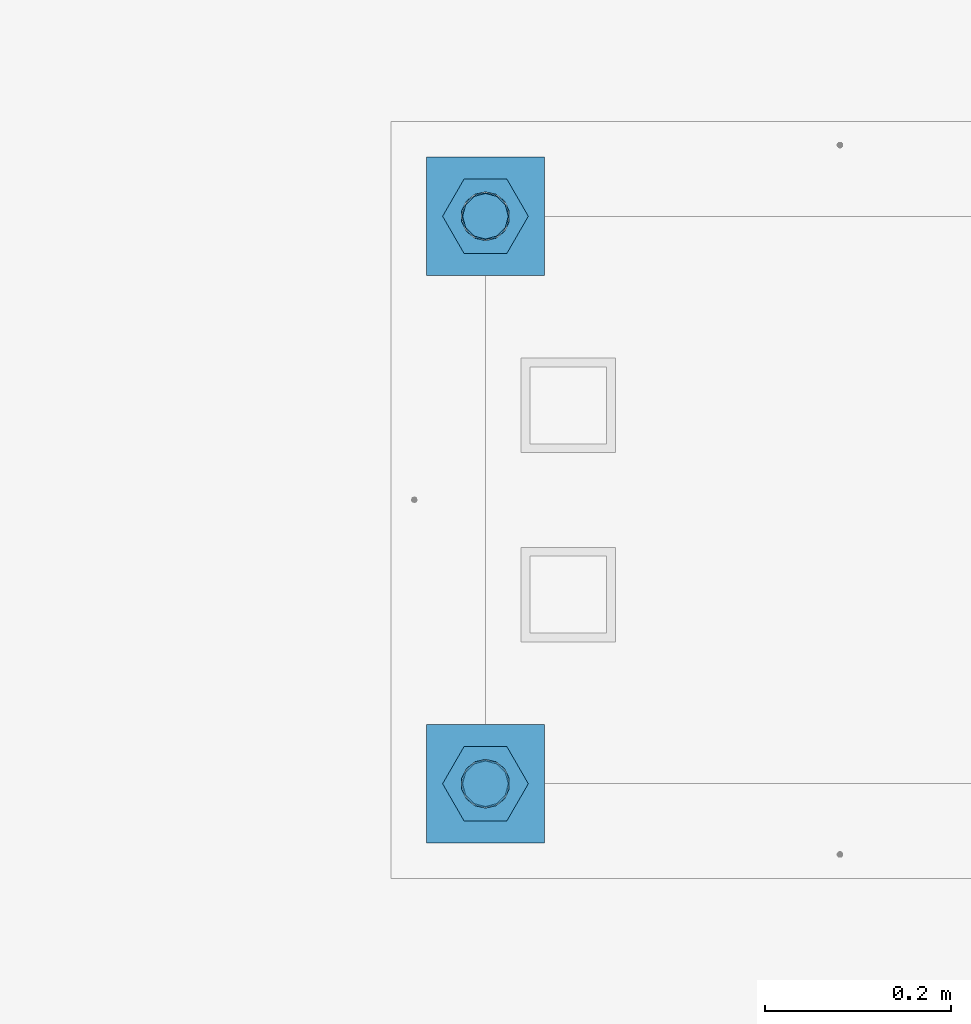
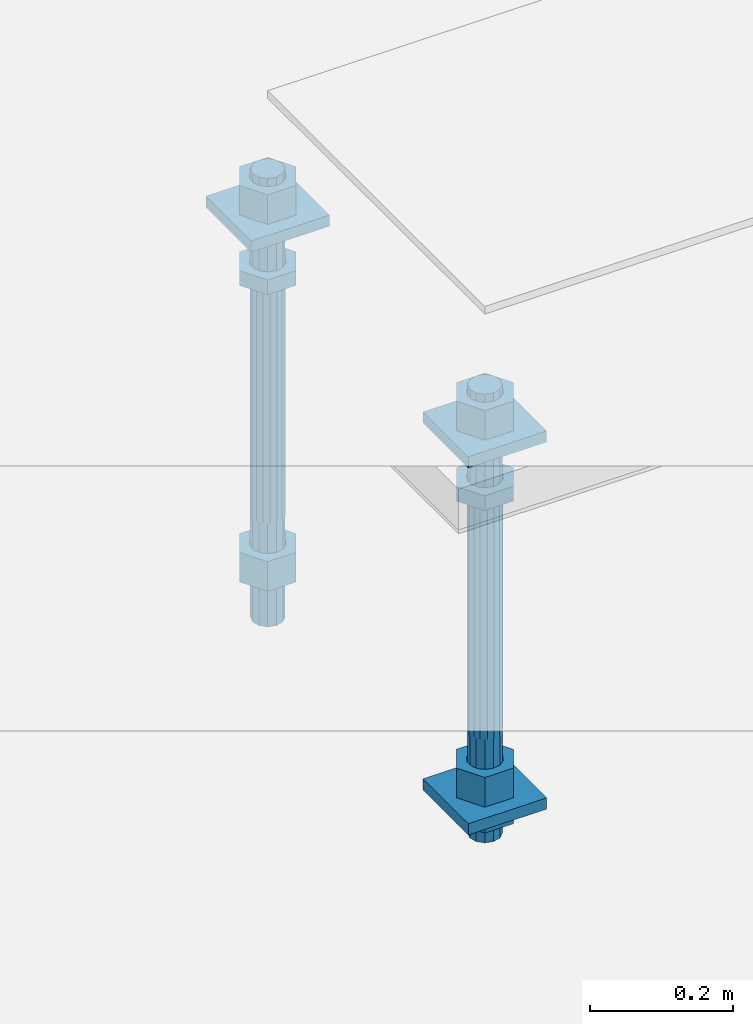
# One storey, part 2693 of 3843: 12 beams, 1 element without a shape of its own.
"""IFC2X3 building model written with IfcOpenShell, lengths in millimetres."""

from ifc_helpers import new_model, si_unit, frame, origin_with_axes, place, context, subcontext, project, spatial, faceted_brep, material, type_object, element, aggregate, save


model = new_model("IFC2X3")

# Units and contexts
model_context = context("Model", 3, precision=1e-05, world=origin_with_axes())
body_context = subcontext(model_context, "Body", "Model", "MODEL_VIEW")
ifc_project = project(units=[si_unit("LENGTHUNIT", "METRE", prefix="MILLI"), si_unit("AREAUNIT", "SQUARE_METRE"), si_unit("VOLUMEUNIT", "CUBIC_METRE"), si_unit("MASSUNIT", "GRAM", prefix="KILO"), si_unit("TIMEUNIT", "SECOND"), si_unit("PLANEANGLEUNIT", "RADIAN"), si_unit("SOLIDANGLEUNIT", "STERADIAN"), si_unit("THERMODYNAMICTEMPERATUREUNIT", "DEGREE_CELSIUS"), si_unit("LUMINOUSINTENSITYUNIT", "LUMEN")], contexts=[model_context])

# Site, building, storey
site_placement = place(None, origin_with_axes())
site = spatial("IfcSite", under=ifc_project, at=site_placement, CompositionType="ELEMENT")
building_placement = place(site_placement, origin_with_axes())
building = spatial("IfcBuilding", under=site, at=building_placement, Name="Undefined", CompositionType="ELEMENT")
storey_placement = place(building_placement, origin_with_axes())
storey = spatial("IfcBuildingStorey", under=building, at=storey_placement, Name="Undefined", CompositionType="ELEMENT", Elevation=0.0)

# Assembly, beams
assembly_placement = place(storey_placement, origin_with_axes())
assembly = element("IfcElementAssembly", 1, at=assembly_placement, inside=storey, Name="TEMPLATE", AssemblyPlace="NOTDEFINED", PredefinedType="RIGID_FRAME")
ifc_material_1 = material(Name="STEEL/A572-50")
beam_type_1 = type_object("IfcBeamType", PredefinedType="NOTDEFINED")
beam_1_placement = place(assembly_placement, frame((104775.0, 38188.9000015259, 29873.575), z_axis=(1.0, 0.0, 0.0), x_axis=(0.0, 1.0, 0.0)))
beam_1 = element("IfcBeam", 2, at=beam_1_placement, type_object=beam_type_1, material=ifc_material_1, Name="WASHER_PLATE", context=body_context, shape_type="Brep", body=[
    faceted_brep([(0.0, 9.52500000000146, -63.5), (0.0, 9.52500000000146, 63.5), (127.0, 9.52500000000146, 63.5), (127.0, 9.52500000000146, -63.5), (0.0, -9.52500000000146, 63.5), (127.0, -9.52500000000146, 63.5), (0.0, -9.52500000000146, -63.5), (127.0, -9.52500000000146, -63.5)], [[[0, 1, 2, 3]], [[1, 4, 5, 2]], [[4, 6, 7, 5]], [[6, 0, 3, 7]], [[5, 7, 3, 2]], [[6, 4, 1, 0]]]),
])
beam_2_placement = place(assembly_placement, frame((104775.0, 38798.5000015259, 29873.575), z_axis=(1.0, 0.0, 0.0), x_axis=(0.0, 1.0, 0.0)))
beam_2 = element("IfcBeam", 3, at=beam_2_placement, type_object=beam_type_1, material=ifc_material_1, Name="WASHER_PLATE", context=body_context, shape_type="Brep", body=[
    faceted_brep([(0.0, 9.52500000000146, -63.5), (0.0, 9.52500000000146, 63.5), (127.0, 9.52500000000146, 63.5), (127.0, 9.52500000000146, -63.5), (0.0, -9.52500000000146, 63.5), (127.0, -9.52500000000146, 63.5), (0.0, -9.52500000000146, -63.5), (127.0, -9.52500000000146, -63.5)], [[[0, 1, 2, 3]], [[1, 4, 5, 2]], [[4, 6, 7, 5]], [[6, 0, 3, 7]], [[5, 7, 3, 2]], [[6, 4, 1, 0]]]),
])
beam_3_placement = place(assembly_placement, frame((104775.0, 38188.9000015259, 29244.925), z_axis=(1.0, 0.0, 0.0), x_axis=(0.0, 1.0, 0.0)))
beam_3 = element("IfcBeam", 4, at=beam_3_placement, type_object=beam_type_1, material=ifc_material_1, Name="WASHER_PLATE", context=body_context, shape_type="Brep", body=[
    faceted_brep([(0.0, 9.52500000000146, -63.5), (0.0, 9.52500000000146, 63.5), (127.0, 9.52500000000146, 63.5), (127.0, 9.52500000000146, -63.5), (0.0, -9.52500000000146, 63.5), (127.0, -9.52500000000146, 63.5), (0.0, -9.52500000000146, -63.5), (127.0, -9.52500000000146, -63.5)], [[[0, 1, 2, 3]], [[1, 4, 5, 2]], [[4, 6, 7, 5]], [[6, 0, 3, 7]], [[5, 7, 3, 2]], [[6, 4, 1, 0]]]),
])
ifc_material_2 = material(Name="STEEL/A36")
beam_type_2 = type_object("IfcBeamType", Name="2_HALF_NUT", PredefinedType="NOTDEFINED")
beam_4_placement = place(assembly_placement, frame((104775.0, 38252.4000015259, 29787.85), z_axis=(0.0, 1.0, 0.0), x_axis=(0.0, 0.0, -1.0)))
beam_4 = element("IfcBeam", 5, at=beam_4_placement, type_object=beam_type_2, material=ifc_material_2, Name="NUT", ObjectType="2_HALF_NUT", context=body_context, shape_type="Brep", body=[
    faceted_brep([(0.0, -46.0369987487793, 0.0), (0.0, -23.0184993743896, -39.869213104248), (25.4000000000015, -23.0184993743896, -39.869213104248), (25.4000000000015, -46.0369987487793, 0.0), (0.0, 23.0184993743896, -39.869213104248), (25.4000000000015, 23.0184993743896, -39.869213104248), (0.0, 46.0369987487793, 0.0), (25.4000000000015, 46.0369987487793, 0.0), (0.0, 23.0184993743896, 39.869213104248), (25.4000000000015, 23.0184993743896, 39.869213104248), (0.0, -23.0184993743896, 39.869213104248), (25.4000000000015, -23.0184993743896, 39.869213104248), (0.0, 0.0, 26.1940002441406), (0.0, 11.3650617044477, 23.5999013092805), (25.4000000000015, 11.3650617044477, 23.5999013092805), (25.4000000000015, 0.0, 26.1940002441406), (0.0, 20.4791109456419, 16.3316083006721), (25.4000000000015, 20.4791109456419, 16.3316083006721), (0.0, 25.5370200498292, 5.82867859874386), (25.4000000000015, 25.5370200498292, 5.82867859874386), (0.0, 25.5370200498292, -5.82867859874386), (25.4000000000015, 25.5370200498292, -5.82867859874386), (0.0, 20.4791109456419, -16.3316083006721), (25.4000000000015, 20.4791109456419, -16.3316083006721), (0.0, 11.3650617044477, -23.5999013092805), (25.4000000000015, 11.3650617044477, -23.5999013092805), (0.0, 0.0, -26.1940002441406), (25.4000000000015, 0.0, -26.1940002441406), (0.0, -11.3650617044477, -23.5999013092805), (25.4000000000015, -11.3650617044477, -23.5999013092805), (0.0, -20.4791109456419, -16.3316083006721), (25.4000000000015, -20.4791109456419, -16.3316083006721), (0.0, -25.5370200498292, -5.82867859874386), (25.4000000000015, -25.5370200498292, -5.82867859874386), (0.0, -25.5370200498292, 5.82867859874386), (25.4000000000015, -25.5370200498292, 5.82867859874386), (0.0, -20.4791109456419, 16.3316083006721), (25.4000000000015, -20.4791109456419, 16.3316083006721), (0.0, -11.3650617044477, 23.5999013092805), (25.4000000000015, -11.3650617044477, 23.5999013092805)], [[[0, 1, 2, 3]], [[1, 4, 5, 2]], [[4, 6, 7, 5]], [[6, 8, 9, 7]], [[8, 10, 11, 9]], [[10, 0, 3, 11]], [[12, 13, 14, 15]], [[13, 16, 17, 14]], [[16, 18, 19, 17]], [[18, 20, 21, 19]], [[20, 22, 23, 21]], [[22, 24, 25, 23]], [[24, 26, 27, 25]], [[26, 28, 29, 27]], [[28, 30, 31, 29]], [[30, 32, 33, 31]], [[32, 34, 35, 33]], [[34, 36, 37, 35]], [[36, 38, 39, 37]], [[38, 12, 15, 39]], [[5, 7, 9, 11, 3, 2], [17, 19, 21, 23, 25, 27, 29, 31, 33, 35, 37, 39, 15, 14]], [[10, 8, 6, 4, 1, 0], [38, 36, 34, 32, 30, 28, 26, 24, 22, 20, 18, 16, 13, 12]]]),
])
beam_5_placement = place(assembly_placement, frame((104775.0, 38252.4000015259, 29235.4), z_axis=(0.0, 1.0, 0.0), x_axis=(0.0, 0.0, -1.0)))
beam_5 = element("IfcBeam", 6, at=beam_5_placement, type_object=beam_type_2, material=ifc_material_2, Name="NUT", ObjectType="2_HALF_NUT", context=body_context, shape_type="Brep", body=[
    faceted_brep([(0.0, -46.0369987487793, 0.0), (0.0, -23.0184993743896, -39.869213104248), (25.4000000000015, -23.0184993743896, -39.869213104248), (25.4000000000015, -46.0369987487793, 0.0), (0.0, 23.0184993743896, -39.869213104248), (25.4000000000015, 23.0184993743896, -39.869213104248), (0.0, 46.0369987487793, 0.0), (25.4000000000015, 46.0369987487793, 0.0), (0.0, 23.0184993743896, 39.869213104248), (25.4000000000015, 23.0184993743896, 39.869213104248), (0.0, -23.0184993743896, 39.869213104248), (25.4000000000015, -23.0184993743896, 39.869213104248), (0.0, 0.0, 26.1940002441406), (0.0, 11.3650617044477, 23.5999013092805), (25.4000000000015, 11.3650617044477, 23.5999013092805), (25.4000000000015, 0.0, 26.1940002441406), (0.0, 20.4791109456419, 16.3316083006721), (25.4000000000015, 20.4791109456419, 16.3316083006721), (0.0, 25.5370200498292, 5.82867859874386), (25.4000000000015, 25.5370200498292, 5.82867859874386), (0.0, 25.5370200498292, -5.82867859874386), (25.4000000000015, 25.5370200498292, -5.82867859874386), (0.0, 20.4791109456419, -16.3316083006721), (25.4000000000015, 20.4791109456419, -16.3316083006721), (0.0, 11.3650617044477, -23.5999013092805), (25.4000000000015, 11.3650617044477, -23.5999013092805), (0.0, 0.0, -26.1940002441406), (25.4000000000015, 0.0, -26.1940002441406), (0.0, -11.3650617044477, -23.5999013092805), (25.4000000000015, -11.3650617044477, -23.5999013092805), (0.0, -20.4791109456419, -16.3316083006721), (25.4000000000015, -20.4791109456419, -16.3316083006721), (0.0, -25.5370200498292, -5.82867859874386), (25.4000000000015, -25.5370200498292, -5.82867859874386), (0.0, -25.5370200498292, 5.82867859874386), (25.4000000000015, -25.5370200498292, 5.82867859874386), (0.0, -20.4791109456419, 16.3316083006721), (25.4000000000015, -20.4791109456419, 16.3316083006721), (0.0, -11.3650617044477, 23.5999013092805), (25.4000000000015, -11.3650617044477, 23.5999013092805)], [[[0, 1, 2, 3]], [[1, 4, 5, 2]], [[4, 6, 7, 5]], [[6, 8, 9, 7]], [[8, 10, 11, 9]], [[10, 0, 3, 11]], [[12, 13, 14, 15]], [[13, 16, 17, 14]], [[16, 18, 19, 17]], [[18, 20, 21, 19]], [[20, 22, 23, 21]], [[22, 24, 25, 23]], [[24, 26, 27, 25]], [[26, 28, 29, 27]], [[28, 30, 31, 29]], [[30, 32, 33, 31]], [[32, 34, 35, 33]], [[34, 36, 37, 35]], [[36, 38, 39, 37]], [[38, 12, 15, 39]], [[5, 7, 9, 11, 3, 2], [17, 19, 21, 23, 25, 27, 29, 31, 33, 35, 37, 39, 15, 14]], [[10, 8, 6, 4, 1, 0], [38, 36, 34, 32, 30, 28, 26, 24, 22, 20, 18, 16, 13, 12]]]),
])
beam_6_placement = place(assembly_placement, frame((104775.0, 38862.0000015259, 29787.85), z_axis=(0.0, 1.0, 0.0), x_axis=(0.0, 0.0, -1.0)))
beam_6 = element("IfcBeam", 7, at=beam_6_placement, type_object=beam_type_2, material=ifc_material_2, Name="NUT", ObjectType="2_HALF_NUT", context=body_context, shape_type="Brep", body=[
    faceted_brep([(0.0, -46.0369987487793, 0.0), (0.0, -23.0184993743896, -39.869213104248), (25.4000000000015, -23.0184993743896, -39.869213104248), (25.4000000000015, -46.0369987487793, 0.0), (0.0, 23.0184993743896, -39.869213104248), (25.4000000000015, 23.0184993743896, -39.869213104248), (0.0, 46.0369987487793, 0.0), (25.4000000000015, 46.0369987487793, 0.0), (0.0, 23.0184993743896, 39.869213104248), (25.4000000000015, 23.0184993743896, 39.869213104248), (0.0, -23.0184993743896, 39.869213104248), (25.4000000000015, -23.0184993743896, 39.869213104248), (0.0, 0.0, 26.1940002441406), (0.0, 11.3650617044477, 23.5999013092805), (25.4000000000015, 11.3650617044477, 23.5999013092805), (25.4000000000015, 0.0, 26.1940002441406), (0.0, 20.4791109456419, 16.3316083006721), (25.4000000000015, 20.4791109456419, 16.3316083006721), (0.0, 25.5370200498292, 5.82867859874386), (25.4000000000015, 25.5370200498292, 5.82867859874386), (0.0, 25.5370200498292, -5.82867859874386), (25.4000000000015, 25.5370200498292, -5.82867859874386), (0.0, 20.4791109456419, -16.3316083006721), (25.4000000000015, 20.4791109456419, -16.3316083006721), (0.0, 11.3650617044477, -23.5999013092805), (25.4000000000015, 11.3650617044477, -23.5999013092805), (0.0, 0.0, -26.1940002441406), (25.4000000000015, 0.0, -26.1940002441406), (0.0, -11.3650617044477, -23.5999013092805), (25.4000000000015, -11.3650617044477, -23.5999013092805), (0.0, -20.4791109456419, -16.3316083006721), (25.4000000000015, -20.4791109456419, -16.3316083006721), (0.0, -25.5370200498292, -5.82867859874386), (25.4000000000015, -25.5370200498292, -5.82867859874386), (0.0, -25.5370200498292, 5.82867859874386), (25.4000000000015, -25.5370200498292, 5.82867859874386), (0.0, -20.4791109456419, 16.3316083006721), (25.4000000000015, -20.4791109456419, 16.3316083006721), (0.0, -11.3650617044477, 23.5999013092805), (25.4000000000015, -11.3650617044477, 23.5999013092805)], [[[0, 1, 2, 3]], [[1, 4, 5, 2]], [[4, 6, 7, 5]], [[6, 8, 9, 7]], [[8, 10, 11, 9]], [[10, 0, 3, 11]], [[12, 13, 14, 15]], [[13, 16, 17, 14]], [[16, 18, 19, 17]], [[18, 20, 21, 19]], [[20, 22, 23, 21]], [[22, 24, 25, 23]], [[24, 26, 27, 25]], [[26, 28, 29, 27]], [[28, 30, 31, 29]], [[30, 32, 33, 31]], [[32, 34, 35, 33]], [[34, 36, 37, 35]], [[36, 38, 39, 37]], [[38, 12, 15, 39]], [[5, 7, 9, 11, 3, 2], [17, 19, 21, 23, 25, 27, 29, 31, 33, 35, 37, 39, 15, 14]], [[10, 8, 6, 4, 1, 0], [38, 36, 34, 32, 30, 28, 26, 24, 22, 20, 18, 16, 13, 12]]]),
])
beam_type_3 = type_object("IfcBeamType", Name="2_HEAVY_HEX_NUT", PredefinedType="NOTDEFINED")
beam_7_placement = place(assembly_placement, frame((104775.0, 38252.4000015259, 29933.9), z_axis=(0.0, 1.0, 0.0), x_axis=(0.0, 0.0, -1.0)))
beam_7 = element("IfcBeam", 8, at=beam_7_placement, type_object=beam_type_3, material=ifc_material_2, Name="NUT", ObjectType="2_HEAVY_HEX_NUT", context=body_context, shape_type="Brep", body=[
    faceted_brep([(0.0, -46.0369987487793, 0.0), (0.0, -23.0184993743896, -39.869213104248), (50.7999999999993, -23.0184993743896, -39.869213104248), (50.7999999999993, -46.0369987487793, 0.0), (0.0, 23.0184993743896, -39.869213104248), (50.7999999999993, 23.0184993743896, -39.869213104248), (0.0, 46.0369987487793, 0.0), (50.7999999999993, 46.0369987487793, 0.0), (0.0, 23.0184993743896, 39.869213104248), (50.7999999999993, 23.0184993743896, 39.869213104248), (0.0, -23.0184993743896, 39.869213104248), (50.7999999999993, -23.0184993743896, 39.869213104248), (0.0, 0.0, 26.1940002441406), (0.0, 11.3650617044477, 23.5999013092805), (50.7999999999993, 11.3650617044477, 23.5999013092805), (50.7999999999993, 0.0, 26.1940002441406), (0.0, 20.4791109456419, 16.3316083006721), (50.7999999999993, 20.4791109456419, 16.3316083006721), (0.0, 25.5370200498292, 5.82867859874386), (50.7999999999993, 25.5370200498292, 5.82867859874386), (0.0, 25.5370200498292, -5.82867859874386), (50.7999999999993, 25.5370200498292, -5.82867859874386), (0.0, 20.4791109456419, -16.3316083006721), (50.7999999999993, 20.4791109456419, -16.3316083006721), (0.0, 11.3650617044477, -23.5999013092805), (50.7999999999993, 11.3650617044477, -23.5999013092805), (0.0, 0.0, -26.1940002441406), (50.7999999999993, 0.0, -26.1940002441406), (0.0, -11.3650617044477, -23.5999013092805), (50.7999999999993, -11.3650617044477, -23.5999013092805), (0.0, -20.4791109456419, -16.3316083006721), (50.7999999999993, -20.4791109456419, -16.3316083006721), (0.0, -25.5370200498292, -5.82867859874386), (50.7999999999993, -25.5370200498292, -5.82867859874386), (0.0, -25.5370200498292, 5.82867859874386), (50.7999999999993, -25.5370200498292, 5.82867859874386), (0.0, -20.4791109456419, 16.3316083006721), (50.7999999999993, -20.4791109456419, 16.3316083006721), (0.0, -11.3650617044477, 23.5999013092805), (50.7999999999993, -11.3650617044477, 23.5999013092805)], [[[0, 1, 2, 3]], [[1, 4, 5, 2]], [[4, 6, 7, 5]], [[6, 8, 9, 7]], [[8, 10, 11, 9]], [[10, 0, 3, 11]], [[12, 13, 14, 15]], [[13, 16, 17, 14]], [[16, 18, 19, 17]], [[18, 20, 21, 19]], [[20, 22, 23, 21]], [[22, 24, 25, 23]], [[24, 26, 27, 25]], [[26, 28, 29, 27]], [[28, 30, 31, 29]], [[30, 32, 33, 31]], [[32, 34, 35, 33]], [[34, 36, 37, 35]], [[36, 38, 39, 37]], [[38, 12, 15, 39]], [[5, 7, 9, 11, 3, 2], [17, 19, 21, 23, 25, 27, 29, 31, 33, 35, 37, 39, 15, 14]], [[10, 8, 6, 4, 1, 0], [38, 36, 34, 32, 30, 28, 26, 24, 22, 20, 18, 16, 13, 12]]]),
])
beam_8_placement = place(assembly_placement, frame((104775.0, 38252.4000015259, 29305.25), z_axis=(0.0, 1.0, 0.0), x_axis=(0.0, 0.0, -1.0)))
beam_8 = element("IfcBeam", 9, at=beam_8_placement, type_object=beam_type_3, material=ifc_material_2, Name="NUT", ObjectType="2_HEAVY_HEX_NUT", context=body_context, shape_type="Brep", body=[
    faceted_brep([(0.0, -46.0369987487793, 0.0), (0.0, -23.0184993743896, -39.869213104248), (50.7999999999993, -23.0184993743896, -39.869213104248), (50.7999999999993, -46.0369987487793, 0.0), (0.0, 23.0184993743896, -39.869213104248), (50.7999999999993, 23.0184993743896, -39.869213104248), (0.0, 46.0369987487793, 0.0), (50.7999999999993, 46.0369987487793, 0.0), (0.0, 23.0184993743896, 39.869213104248), (50.7999999999993, 23.0184993743896, 39.869213104248), (0.0, -23.0184993743896, 39.869213104248), (50.7999999999993, -23.0184993743896, 39.869213104248), (0.0, 0.0, 26.1940002441406), (0.0, 11.3650617044477, 23.5999013092805), (50.7999999999993, 11.3650617044477, 23.5999013092805), (50.7999999999993, 0.0, 26.1940002441406), (0.0, 20.4791109456419, 16.3316083006721), (50.7999999999993, 20.4791109456419, 16.3316083006721), (0.0, 25.5370200498292, 5.82867859874386), (50.7999999999993, 25.5370200498292, 5.82867859874386), (0.0, 25.5370200498292, -5.82867859874386), (50.7999999999993, 25.5370200498292, -5.82867859874386), (0.0, 20.4791109456419, -16.3316083006721), (50.7999999999993, 20.4791109456419, -16.3316083006721), (0.0, 11.3650617044477, -23.5999013092805), (50.7999999999993, 11.3650617044477, -23.5999013092805), (0.0, 0.0, -26.1940002441406), (50.7999999999993, 0.0, -26.1940002441406), (0.0, -11.3650617044477, -23.5999013092805), (50.7999999999993, -11.3650617044477, -23.5999013092805), (0.0, -20.4791109456419, -16.3316083006721), (50.7999999999993, -20.4791109456419, -16.3316083006721), (0.0, -25.5370200498292, -5.82867859874386), (50.7999999999993, -25.5370200498292, -5.82867859874386), (0.0, -25.5370200498292, 5.82867859874386), (50.7999999999993, -25.5370200498292, 5.82867859874386), (0.0, -20.4791109456419, 16.3316083006721), (50.7999999999993, -20.4791109456419, 16.3316083006721), (0.0, -11.3650617044477, 23.5999013092805), (50.7999999999993, -11.3650617044477, 23.5999013092805)], [[[0, 1, 2, 3]], [[1, 4, 5, 2]], [[4, 6, 7, 5]], [[6, 8, 9, 7]], [[8, 10, 11, 9]], [[10, 0, 3, 11]], [[12, 13, 14, 15]], [[13, 16, 17, 14]], [[16, 18, 19, 17]], [[18, 20, 21, 19]], [[20, 22, 23, 21]], [[22, 24, 25, 23]], [[24, 26, 27, 25]], [[26, 28, 29, 27]], [[28, 30, 31, 29]], [[30, 32, 33, 31]], [[32, 34, 35, 33]], [[34, 36, 37, 35]], [[36, 38, 39, 37]], [[38, 12, 15, 39]], [[5, 7, 9, 11, 3, 2], [17, 19, 21, 23, 25, 27, 29, 31, 33, 35, 37, 39, 15, 14]], [[10, 8, 6, 4, 1, 0], [38, 36, 34, 32, 30, 28, 26, 24, 22, 20, 18, 16, 13, 12]]]),
])
beam_9_placement = place(assembly_placement, frame((104775.0, 38862.0000015259, 29933.9), z_axis=(0.0, 1.0, 0.0), x_axis=(0.0, 0.0, -1.0)))
beam_9 = element("IfcBeam", 10, at=beam_9_placement, type_object=beam_type_3, material=ifc_material_2, Name="NUT", ObjectType="2_HEAVY_HEX_NUT", context=body_context, shape_type="Brep", body=[
    faceted_brep([(0.0, -46.0369987487793, 0.0), (0.0, -23.0184993743896, -39.869213104248), (50.7999999999993, -23.0184993743896, -39.869213104248), (50.7999999999993, -46.0369987487793, 0.0), (0.0, 23.0184993743896, -39.869213104248), (50.7999999999993, 23.0184993743896, -39.869213104248), (0.0, 46.0369987487793, 0.0), (50.7999999999993, 46.0369987487793, 0.0), (0.0, 23.0184993743896, 39.869213104248), (50.7999999999993, 23.0184993743896, 39.869213104248), (0.0, -23.0184993743896, 39.869213104248), (50.7999999999993, -23.0184993743896, 39.869213104248), (0.0, 0.0, 26.1940002441406), (0.0, 11.3650617044477, 23.5999013092805), (50.7999999999993, 11.3650617044477, 23.5999013092805), (50.7999999999993, 0.0, 26.1940002441406), (0.0, 20.4791109456419, 16.3316083006721), (50.7999999999993, 20.4791109456419, 16.3316083006721), (0.0, 25.5370200498292, 5.82867859874386), (50.7999999999993, 25.5370200498292, 5.82867859874386), (0.0, 25.5370200498292, -5.82867859874386), (50.7999999999993, 25.5370200498292, -5.82867859874386), (0.0, 20.4791109456419, -16.3316083006721), (50.7999999999993, 20.4791109456419, -16.3316083006721), (0.0, 11.3650617044477, -23.5999013092805), (50.7999999999993, 11.3650617044477, -23.5999013092805), (0.0, 0.0, -26.1940002441406), (50.7999999999993, 0.0, -26.1940002441406), (0.0, -11.3650617044477, -23.5999013092805), (50.7999999999993, -11.3650617044477, -23.5999013092805), (0.0, -20.4791109456419, -16.3316083006721), (50.7999999999993, -20.4791109456419, -16.3316083006721), (0.0, -25.5370200498292, -5.82867859874386), (50.7999999999993, -25.5370200498292, -5.82867859874386), (0.0, -25.5370200498292, 5.82867859874386), (50.7999999999993, -25.5370200498292, 5.82867859874386), (0.0, -20.4791109456419, 16.3316083006721), (50.7999999999993, -20.4791109456419, 16.3316083006721), (0.0, -11.3650617044477, 23.5999013092805), (50.7999999999993, -11.3650617044477, 23.5999013092805)], [[[0, 1, 2, 3]], [[1, 4, 5, 2]], [[4, 6, 7, 5]], [[6, 8, 9, 7]], [[8, 10, 11, 9]], [[10, 0, 3, 11]], [[12, 13, 14, 15]], [[13, 16, 17, 14]], [[16, 18, 19, 17]], [[18, 20, 21, 19]], [[20, 22, 23, 21]], [[22, 24, 25, 23]], [[24, 26, 27, 25]], [[26, 28, 29, 27]], [[28, 30, 31, 29]], [[30, 32, 33, 31]], [[32, 34, 35, 33]], [[34, 36, 37, 35]], [[36, 38, 39, 37]], [[38, 12, 15, 39]], [[5, 7, 9, 11, 3, 2], [17, 19, 21, 23, 25, 27, 29, 31, 33, 35, 37, 39, 15, 14]], [[10, 8, 6, 4, 1, 0], [38, 36, 34, 32, 30, 28, 26, 24, 22, 20, 18, 16, 13, 12]]]),
])
beam_10_placement = place(assembly_placement, frame((104775.0, 38862.0000015259, 29305.25), z_axis=(0.0, 1.0, 0.0), x_axis=(0.0, 0.0, -1.0)))
beam_10 = element("IfcBeam", 11, at=beam_10_placement, type_object=beam_type_3, material=ifc_material_2, Name="NUT", ObjectType="2_HEAVY_HEX_NUT", context=body_context, shape_type="Brep", body=[
    faceted_brep([(0.0, -46.0369987487793, 0.0), (0.0, -23.0184993743896, -39.869213104248), (50.7999999999993, -23.0184993743896, -39.869213104248), (50.7999999999993, -46.0369987487793, 0.0), (0.0, 23.0184993743896, -39.869213104248), (50.7999999999993, 23.0184993743896, -39.869213104248), (0.0, 46.0369987487793, 0.0), (50.7999999999993, 46.0369987487793, 0.0), (0.0, 23.0184993743896, 39.869213104248), (50.7999999999993, 23.0184993743896, 39.869213104248), (0.0, -23.0184993743896, 39.869213104248), (50.7999999999993, -23.0184993743896, 39.869213104248), (0.0, 0.0, 26.1940002441406), (0.0, 11.3650617044477, 23.5999013092805), (50.7999999999993, 11.3650617044477, 23.5999013092805), (50.7999999999993, 0.0, 26.1940002441406), (0.0, 20.4791109456419, 16.3316083006721), (50.7999999999993, 20.4791109456419, 16.3316083006721), (0.0, 25.5370200498292, 5.82867859874386), (50.7999999999993, 25.5370200498292, 5.82867859874386), (0.0, 25.5370200498292, -5.82867859874386), (50.7999999999993, 25.5370200498292, -5.82867859874386), (0.0, 20.4791109456419, -16.3316083006721), (50.7999999999993, 20.4791109456419, -16.3316083006721), (0.0, 11.3650617044477, -23.5999013092805), (50.7999999999993, 11.3650617044477, -23.5999013092805), (0.0, 0.0, -26.1940002441406), (50.7999999999993, 0.0, -26.1940002441406), (0.0, -11.3650617044477, -23.5999013092805), (50.7999999999993, -11.3650617044477, -23.5999013092805), (0.0, -20.4791109456419, -16.3316083006721), (50.7999999999993, -20.4791109456419, -16.3316083006721), (0.0, -25.5370200498292, -5.82867859874386), (50.7999999999993, -25.5370200498292, -5.82867859874386), (0.0, -25.5370200498292, 5.82867859874386), (50.7999999999993, -25.5370200498292, 5.82867859874386), (0.0, -20.4791109456419, 16.3316083006721), (50.7999999999993, -20.4791109456419, 16.3316083006721), (0.0, -11.3650617044477, 23.5999013092805), (50.7999999999993, -11.3650617044477, 23.5999013092805)], [[[0, 1, 2, 3]], [[1, 4, 5, 2]], [[4, 6, 7, 5]], [[6, 8, 9, 7]], [[8, 10, 11, 9]], [[10, 0, 3, 11]], [[12, 13, 14, 15]], [[13, 16, 17, 14]], [[16, 18, 19, 17]], [[18, 20, 21, 19]], [[20, 22, 23, 21]], [[22, 24, 25, 23]], [[24, 26, 27, 25]], [[26, 28, 29, 27]], [[28, 30, 31, 29]], [[30, 32, 33, 31]], [[32, 34, 35, 33]], [[34, 36, 37, 35]], [[36, 38, 39, 37]], [[38, 12, 15, 39]], [[5, 7, 9, 11, 3, 2], [17, 19, 21, 23, 25, 27, 29, 31, 33, 35, 37, 39, 15, 14]], [[10, 8, 6, 4, 1, 0], [38, 36, 34, 32, 30, 28, 26, 24, 22, 20, 18, 16, 13, 12]]]),
])
ifc_material_3 = material()
beam_type_4 = type_object("IfcBeamType", PredefinedType="NOTDEFINED")
beam_11_placement = place(assembly_placement, frame((104775.000001526, 38862.0, 29762.45), z_axis=(1.0, 0.0, 0.0), x_axis=(0.0, 0.0, -1.0)))
beam_11 = element("IfcBeam", 12, at=beam_11_placement, type_object=beam_type_4, material=ifc_material_3, Name="ANCHOR_ROD", context=body_context, shape_type="Brep", body=[
    faceted_brep([(0.0, -23.4665401257807, -9.72015918207035), (0.0, -17.9605122421344, -17.9605122421417), (406.399999999998, -17.9605122421344, -17.9605122421417), (406.399999999998, -23.4665401257807, -9.72015918207035), (0.0, -9.72015918207762, -23.466540125788), (406.399999999998, -9.72015918207762, -23.466540125788), (0.0, 0.0, -25.4000000000015), (406.399999999998, 0.0, -25.4000000000015), (0.0, 9.72015918207762, -23.466540125788), (406.399999999998, 9.72015918207762, -23.466540125788), (0.0, 17.9605122421344, -17.9605122421417), (406.399999999998, 17.9605122421344, -17.9605122421417), (0.0, 23.4665401257807, -9.72015918207035), (406.399999999998, 23.4665401257807, -9.72015918207035), (0.0, 25.3999996185303, 0.0), (406.399999999998, 25.3999999999942, 0.0), (0.0, 23.4665401257807, 9.72015918207035), (406.399999999998, 23.4665401257807, 9.72015918207035), (0.0, 17.9605122421344, 17.9605122421417), (406.399999999998, 17.9605122421344, 17.9605122421417), (0.0, 9.72015918207762, 23.466540125788), (406.399999999998, 9.72015918207762, 23.466540125788), (0.0, 0.0, 25.4000000000015), (406.399999999998, 0.0, 25.4000000000015), (0.0, -9.72015918207762, 23.466540125788), (406.399999999998, -9.72015918207762, 23.466540125788), (0.0, -17.9605122421344, 17.9605122421417), (406.399999999998, -17.9605122421344, 17.9605122421417), (0.0, -23.4665401257807, 9.72015918207035), (406.399999999998, -23.4665401257807, 9.72015918207035), (0.0, -25.3999996185303, 0.0), (406.399999999998, -25.3999999999942, 0.0), (584.200000000001, -12.2499999999854, -21.2176223927163), (584.200000000001, 1.45519152283669e-11, -24.5), (584.200000000001, 12.2500000000146, -21.2176223927163), (584.200000000001, 21.2176223927381, -12.25), (584.200000000001, 24.5000000000146, 0.0), (584.200000000001, 21.2176223927381, 12.25), (584.200000000001, 12.2500000000146, 21.2176223927163), (584.200000000001, 1.45519152283669e-11, 24.5), (584.200000000001, -12.2499999999854, 21.2176223927163), (584.200000000001, -21.217622392709, 12.25), (584.200000000001, -24.4999999999854, 0.0), (584.200000000001, -21.217622392709, -12.25), (406.399999999998, -24.4999999999854, 0.0), (406.399999999998, -21.217622392709, -12.25), (406.399999999998, -12.2499999999854, -21.2176223927163), (406.399999999998, 1.45519152283669e-11, -24.5), (406.399999999998, 12.2500000000146, -21.2176223927163), (406.399999999998, 21.2176223927381, -12.25), (406.399999999998, 24.5000000000146, 0.0), (406.399999999998, 21.2176223927381, 12.25), (406.399999999998, 12.2500000000146, 21.2176223927163), (406.399999999998, 1.45519152283669e-11, 24.5), (406.399999999998, -12.2499999999854, 21.2176223927163), (406.399999999998, -21.217622392709, 12.25), (0.0, 12.2500000000146, 21.2176223927163), (0.0, 1.45519152283669e-11, 24.5), (0.0, -12.2499999999854, 21.2176223927163), (0.0, -21.217622392709, 12.25), (0.0, -24.4999999999854, 0.0), (0.0, -21.217622392709, -12.25), (0.0, -12.2499999999854, -21.2176223927163), (0.0, 1.45519152283669e-11, -24.5), (0.0, 12.2500000000146, -21.2176223927163), (0.0, 21.2176223927381, -12.25), (0.0, 24.5000000000146, 0.0), (0.0, 21.2176223927381, 12.25), (-184.150000000001, -21.217622392709, 12.25), (-184.150000000001, -12.2499999999854, 21.2176223927163), (-184.150000000001, 1.45519152283669e-11, 24.5), (-184.150000000001, 12.2500000000146, 21.2176223927163), (-184.150000000001, 21.2176223927381, 12.25), (-184.150000000001, 24.5000000000146, 0.0), (-184.150000000001, 21.2176223927381, -12.25), (-184.150000000001, 12.2500000000146, -21.2176223927163), (-184.150000000001, 1.45519152283669e-11, -24.5), (-184.150000000001, -12.2499999999854, -21.2176223927163), (-184.150000000001, -21.217622392709, -12.25), (-184.150000000001, -24.4999999999854, 0.0)], [[[0, 1, 2, 3]], [[1, 4, 5, 2]], [[4, 6, 7, 5]], [[6, 8, 9, 7]], [[8, 10, 11, 9]], [[10, 12, 13, 11]], [[12, 14, 15, 13]], [[14, 16, 17, 15]], [[16, 18, 19, 17]], [[18, 20, 21, 19]], [[20, 22, 23, 21]], [[22, 24, 25, 23]], [[24, 26, 27, 25]], [[26, 28, 29, 27]], [[28, 30, 31, 29]], [[32, 33, 34, 35, 36, 37, 38, 39, 40, 41, 42, 43]], [[43, 42, 44, 45]], [[32, 43, 45, 46]], [[33, 32, 46, 47]], [[34, 33, 47, 48]], [[35, 34, 48, 49]], [[36, 35, 49, 50]], [[37, 36, 50, 51]], [[38, 37, 51, 52]], [[39, 38, 52, 53]], [[40, 39, 53, 54]], [[41, 40, 54, 55]], [[42, 41, 55, 44]], [[2, 5, 7, 9, 11, 13, 15, 17, 19, 21, 23, 25, 27, 29, 31, 3], [54, 53, 52, 51, 50, 49, 48, 47, 46, 45, 44, 55]], [[30, 0, 3, 31]], [[28, 26, 24, 22, 20, 18, 16, 14, 12, 10, 8, 6, 4, 1, 0, 30], [56, 57, 58, 59, 60, 61, 62, 63, 64, 65, 66, 67]], [[68, 69, 70, 71, 72, 73, 74, 75, 76, 77, 78, 79]], [[71, 70, 57, 56]], [[72, 71, 56, 67]], [[73, 72, 67, 66]], [[74, 73, 66, 65]], [[75, 74, 65, 64]], [[76, 75, 64, 63]], [[77, 76, 63, 62]], [[78, 77, 62, 61]], [[79, 78, 61, 60]], [[68, 79, 60, 59]], [[69, 68, 59, 58]], [[70, 69, 58, 57]]]),
])
beam_12_placement = place(assembly_placement, frame((104775.000001526, 38252.4, 29762.45), z_axis=(1.0, 0.0, 0.0), x_axis=(0.0, 0.0, -1.0)))
beam_12 = element("IfcBeam", 13, at=beam_12_placement, type_object=beam_type_4, material=ifc_material_3, Name="ANCHOR_ROD", context=body_context, shape_type="Brep", body=[
    faceted_brep([(0.0, -23.4665401257807, -9.72015918207035), (0.0, -17.9605122421344, -17.9605122421417), (406.399999999998, -17.9605122421344, -17.9605122421417), (406.399999999998, -23.4665401257807, -9.72015918207035), (0.0, -9.72015918207762, -23.466540125788), (406.399999999998, -9.72015918207762, -23.466540125788), (0.0, 0.0, -25.4000000000015), (406.399999999998, 0.0, -25.4000000000015), (0.0, 9.72015918207762, -23.466540125788), (406.399999999998, 9.72015918207762, -23.466540125788), (0.0, 17.9605122421344, -17.9605122421417), (406.399999999998, 17.9605122421344, -17.9605122421417), (0.0, 23.4665401257807, -9.72015918207035), (406.399999999998, 23.4665401257807, -9.72015918207035), (0.0, 25.3999996185303, 0.0), (406.399999999998, 25.3999999999942, 0.0), (0.0, 23.4665401257807, 9.72015918207035), (406.399999999998, 23.4665401257807, 9.72015918207035), (0.0, 17.9605122421344, 17.9605122421417), (406.399999999998, 17.9605122421344, 17.9605122421417), (0.0, 9.72015918207762, 23.466540125788), (406.399999999998, 9.72015918207762, 23.466540125788), (0.0, 0.0, 25.4000000000015), (406.399999999998, 0.0, 25.4000000000015), (0.0, -9.72015918207762, 23.466540125788), (406.399999999998, -9.72015918207762, 23.466540125788), (0.0, -17.9605122421344, 17.9605122421417), (406.399999999998, -17.9605122421344, 17.9605122421417), (0.0, -23.4665401257807, 9.72015918207035), (406.399999999998, -23.4665401257807, 9.72015918207035), (0.0, -25.3999996185303, 0.0), (406.399999999998, -25.3999999999942, 0.0), (584.200000000001, -12.2499999999854, -21.2176223927163), (584.200000000001, 1.45519152283669e-11, -24.5), (584.200000000001, 12.2500000000146, -21.2176223927163), (584.200000000001, 21.2176223927381, -12.25), (584.200000000001, 24.5000000000146, 0.0), (584.200000000001, 21.2176223927381, 12.25), (584.200000000001, 12.2500000000146, 21.2176223927163), (584.200000000001, 1.45519152283669e-11, 24.5), (584.200000000001, -12.2499999999854, 21.2176223927163), (584.200000000001, -21.217622392709, 12.25), (584.200000000001, -24.4999999999854, 0.0), (584.200000000001, -21.217622392709, -12.25), (406.399999999998, -24.4999999999854, 0.0), (406.399999999998, -21.217622392709, -12.25), (406.399999999998, -12.2499999999854, -21.2176223927163), (406.399999999998, 1.45519152283669e-11, -24.5), (406.399999999998, 12.2500000000146, -21.2176223927163), (406.399999999998, 21.2176223927381, -12.25), (406.399999999998, 24.5000000000146, 0.0), (406.399999999998, 21.2176223927381, 12.25), (406.399999999998, 12.2500000000146, 21.2176223927163), (406.399999999998, 1.45519152283669e-11, 24.5), (406.399999999998, -12.2499999999854, 21.2176223927163), (406.399999999998, -21.217622392709, 12.25), (0.0, 12.2500000000146, 21.2176223927163), (0.0, 1.45519152283669e-11, 24.5), (0.0, -12.2499999999854, 21.2176223927163), (0.0, -21.217622392709, 12.25), (0.0, -24.4999999999854, 0.0), (0.0, -21.217622392709, -12.25), (0.0, -12.2499999999854, -21.2176223927163), (0.0, 1.45519152283669e-11, -24.5), (0.0, 12.2500000000146, -21.2176223927163), (0.0, 21.2176223927381, -12.25), (0.0, 24.5000000000146, 0.0), (0.0, 21.2176223927381, 12.25), (-184.150000000001, -21.217622392709, 12.25), (-184.150000000001, -12.2499999999854, 21.2176223927163), (-184.150000000001, 1.45519152283669e-11, 24.5), (-184.150000000001, 12.2500000000146, 21.2176223927163), (-184.150000000001, 21.2176223927381, 12.25), (-184.150000000001, 24.5000000000146, 0.0), (-184.150000000001, 21.2176223927381, -12.25), (-184.150000000001, 12.2500000000146, -21.2176223927163), (-184.150000000001, 1.45519152283669e-11, -24.5), (-184.150000000001, -12.2499999999854, -21.2176223927163), (-184.150000000001, -21.217622392709, -12.25), (-184.150000000001, -24.4999999999854, 0.0)], [[[0, 1, 2, 3]], [[1, 4, 5, 2]], [[4, 6, 7, 5]], [[6, 8, 9, 7]], [[8, 10, 11, 9]], [[10, 12, 13, 11]], [[12, 14, 15, 13]], [[14, 16, 17, 15]], [[16, 18, 19, 17]], [[18, 20, 21, 19]], [[20, 22, 23, 21]], [[22, 24, 25, 23]], [[24, 26, 27, 25]], [[26, 28, 29, 27]], [[28, 30, 31, 29]], [[32, 33, 34, 35, 36, 37, 38, 39, 40, 41, 42, 43]], [[43, 42, 44, 45]], [[32, 43, 45, 46]], [[33, 32, 46, 47]], [[34, 33, 47, 48]], [[35, 34, 48, 49]], [[36, 35, 49, 50]], [[37, 36, 50, 51]], [[38, 37, 51, 52]], [[39, 38, 52, 53]], [[40, 39, 53, 54]], [[41, 40, 54, 55]], [[42, 41, 55, 44]], [[2, 5, 7, 9, 11, 13, 15, 17, 19, 21, 23, 25, 27, 29, 31, 3], [54, 53, 52, 51, 50, 49, 48, 47, 46, 45, 44, 55]], [[30, 0, 3, 31]], [[28, 26, 24, 22, 20, 18, 16, 14, 12, 10, 8, 6, 4, 1, 0, 30], [56, 57, 58, 59, 60, 61, 62, 63, 64, 65, 66, 67]], [[68, 69, 70, 71, 72, 73, 74, 75, 76, 77, 78, 79]], [[71, 70, 57, 56]], [[72, 71, 56, 67]], [[73, 72, 67, 66]], [[74, 73, 66, 65]], [[75, 74, 65, 64]], [[76, 75, 64, 63]], [[77, 76, 63, 62]], [[78, 77, 62, 61]], [[79, 78, 61, 60]], [[68, 79, 60, 59]], [[69, 68, 59, 58]], [[70, 69, 58, 57]]]),
])
aggregate(assembly, [beam_11, beam_12, beam_1, beam_2, beam_4, beam_7, beam_8, beam_5, beam_3, beam_6, beam_9, beam_10])

save(model, "model.ifc")
